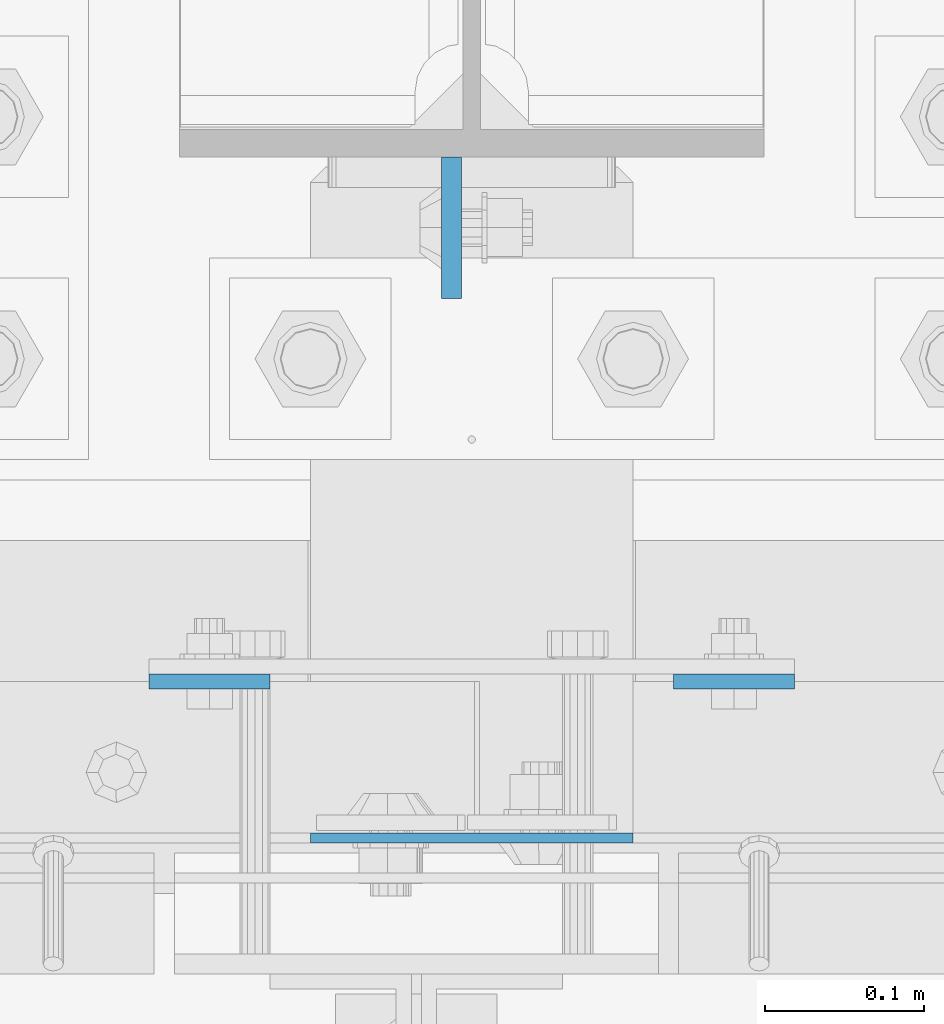
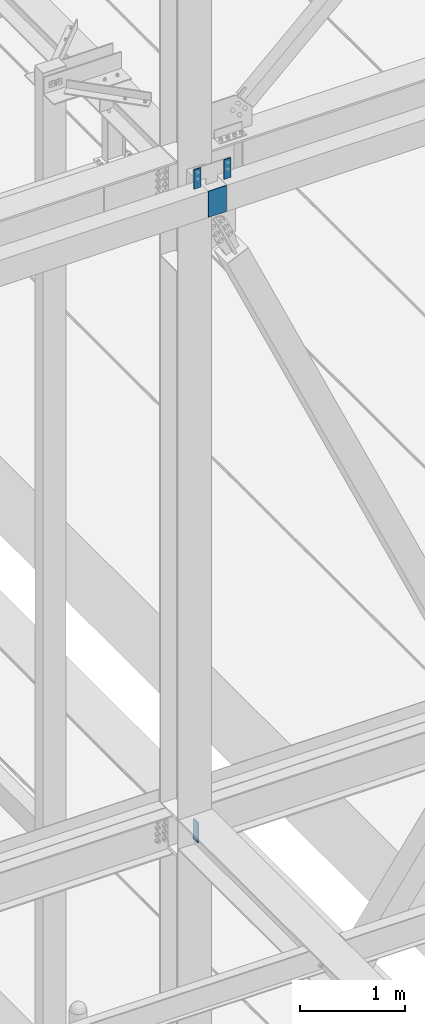
# One storey, part 1459 of 3843: 4 columns, 3 elements without a shape of their own.
"""IFC2X3 building model written with IfcOpenShell, lengths in millimetres."""

from ifc_helpers import new_model, si_unit, frame, origin_with_axes, place, context, subcontext, project, spatial, faceted_brep, material, type_object, element, aggregate, save


model = new_model("IFC2X3")

# Units and contexts
model_context = context("Model", 3, precision=1e-05, world=origin_with_axes())
body_context = subcontext(model_context, "Body", "Model", "MODEL_VIEW")
ifc_project = project(units=[si_unit("LENGTHUNIT", "METRE", prefix="MILLI"), si_unit("AREAUNIT", "SQUARE_METRE"), si_unit("VOLUMEUNIT", "CUBIC_METRE"), si_unit("MASSUNIT", "GRAM", prefix="KILO"), si_unit("TIMEUNIT", "SECOND"), si_unit("PLANEANGLEUNIT", "RADIAN"), si_unit("SOLIDANGLEUNIT", "STERADIAN"), si_unit("THERMODYNAMICTEMPERATUREUNIT", "DEGREE_CELSIUS"), si_unit("LUMINOUSINTENSITYUNIT", "LUMEN")], contexts=[model_context])

# Site, building, storey
site_placement = place(None, origin_with_axes())
site = spatial("IfcSite", under=ifc_project, at=site_placement, CompositionType="ELEMENT")
building_placement = place(site_placement, origin_with_axes())
building = spatial("IfcBuilding", under=site, at=building_placement, Name="Undefined", CompositionType="ELEMENT")
storey_placement = place(building_placement, origin_with_axes())
storey = spatial("IfcBuildingStorey", under=building, at=storey_placement, Name="Undefined", CompositionType="ELEMENT", Elevation=0.0)

# Assembly, column
assembly_1_placement = place(storey_placement, origin_with_axes())
assembly_1 = element("IfcElementAssembly", 1, at=assembly_1_placement, inside=storey, Name="COLUMN", AssemblyPlace="NOTDEFINED", PredefinedType="RIGID_FRAME")
ifc_material = material(Name="STEEL/A572-50")
column_type_1 = type_object("IfcColumnType", PredefinedType="NOTDEFINED")
column_1_placement = place(assembly_1_placement, frame((42062.4000000001, 25009.475, 42062.4000000001), z_axis=(1.0, 0.0, 0.0), x_axis=(0.0, 0.0, 1.0)))
column_1 = element("IfcColumn", 2, at=column_1_placement, type_object=column_type_1, material=ifc_material, Name="PLATE", context=body_context, shape_type="Brep", body=[
    faceted_brep([(0.0, 3.17499999999927, -101.600000000006), (0.0, 3.17499999999927, 101.600000000006), (304.800000000003, 3.17499999999927, 101.600000000006), (304.800000000003, 3.17499999999927, -101.600000000006), (0.0, -3.17499999999927, 101.600000000006), (304.800000000003, -3.17499999999927, 101.600000000006), (0.0, -3.17499999999927, -101.600000000006), (304.800000000003, -3.17499999999927, -101.600000000006)], [[[0, 1, 2, 3]], [[1, 4, 5, 2]], [[4, 6, 7, 5]], [[6, 0, 3, 7]], [[5, 7, 3, 2]], [[6, 4, 1, 0]]]),
])

assembly_2_placement = place(storey_placement, origin_with_axes())
assembly_2 = element("IfcElementAssembly", 3, at=assembly_2_placement, inside=storey, Name="GIRT", AssemblyPlace="NOTDEFINED", PredefinedType="RIGID_FRAME")
column_type_2 = type_object("IfcColumnType", PredefinedType="NOTDEFINED")
column_2_placement = place(assembly_2_placement, frame((41897.3000000001, 25107.9, 42367.2000000001), z_axis=(-1.0, 0.0, 0.0), x_axis=(0.0, 0.0, 1.0)))
column_2 = element("IfcColumn", 4, at=column_2_placement, type_object=column_type_2, material=ifc_material, Name="PLATE", context=body_context, shape_type="Brep", body=[
    faceted_brep([(0.0, 4.76250000000073, -38.0999999999985), (0.0, 4.76250000000073, 38.0999999999985), (228.599999999999, 4.76249999999709, 38.1000000000058), (228.599999999999, 4.76249999999709, -38.1000000000058), (0.0, -4.76250000000073, 38.0999999999985), (228.599999999999, -4.76249999999709, 38.1000000000058), (0.0, -4.76250000000073, -38.0999999999985), (228.599999999999, -4.76249999999709, -38.1000000000058)], [[[0, 1, 2, 3]], [[1, 4, 5, 2]], [[4, 6, 7, 5]], [[6, 0, 3, 7]], [[5, 7, 3, 2]], [[6, 4, 1, 0]]]),
])
aggregate(assembly_2, [column_2])

assembly_3_placement = place(storey_placement, origin_with_axes())
assembly_3 = element("IfcElementAssembly", 5, at=assembly_3_placement, inside=storey, Name="GIRT", AssemblyPlace="NOTDEFINED", PredefinedType="RIGID_FRAME")
column_3_placement = place(assembly_3_placement, frame((42227.5000000001, 25107.9, 42367.2000000001), z_axis=(-1.0, 0.0, 0.0), x_axis=(0.0, 0.0, 1.0)))
column_3 = element("IfcColumn", 6, at=column_3_placement, type_object=column_type_2, material=ifc_material, Name="PLATE", context=body_context, shape_type="Brep", body=[
    faceted_brep([(0.0, 4.76250000000073, -38.0999999999985), (0.0, 4.76250000000073, 38.0999999999985), (228.599999999999, 4.76249999999709, 38.1000000000058), (228.599999999999, 4.76249999999709, -38.1000000000058), (0.0, -4.76250000000073, 38.0999999999985), (228.599999999999, -4.76249999999709, 38.1000000000058), (0.0, -4.76250000000073, -38.0999999999985), (228.599999999999, -4.76249999999709, -38.1000000000058)], [[[0, 1, 2, 3]], [[1, 4, 5, 2]], [[4, 6, 7, 5]], [[6, 0, 3, 7]], [[5, 7, 3, 2]], [[6, 4, 1, 0]]]),
])
aggregate(assembly_3, [column_3])

# Column
column_type_3 = type_object("IfcColumnType", PredefinedType="NOTDEFINED")
column_4_placement = place(assembly_1_placement, frame((42049.7, 25393.65, 34531.2999990633), z_axis=(0.0, 1.0, 0.0), x_axis=(0.0, 0.0, 1.0)))
column_4 = element("IfcColumn", 7, at=column_4_placement, type_object=column_type_3, material=ifc_material, Name="PLATE", context=body_context, shape_type="Brep", body=[
    faceted_brep([(0.0, 6.34999999999854, -44.4500000000007), (0.0, 6.34999999999854, 44.4500000000007), (228.599999999999, 6.34999999999854, 44.4500000000007), (228.599999999999, 6.34999999999854, -44.4500000000007), (0.0, -6.34999999999854, 44.4500000000007), (228.599999999999, -6.34999999999854, 44.4500000000007), (0.0, -6.34999999999854, -44.4500000000007), (228.599999999999, -6.34999999999854, -44.4500000000007)], [[[0, 1, 2, 3]], [[1, 4, 5, 2]], [[4, 6, 7, 5]], [[6, 0, 3, 7]], [[5, 7, 3, 2]], [[6, 4, 1, 0]]]),
])

aggregate(assembly_1, [column_1, column_4])

save(model, "model.ifc")
